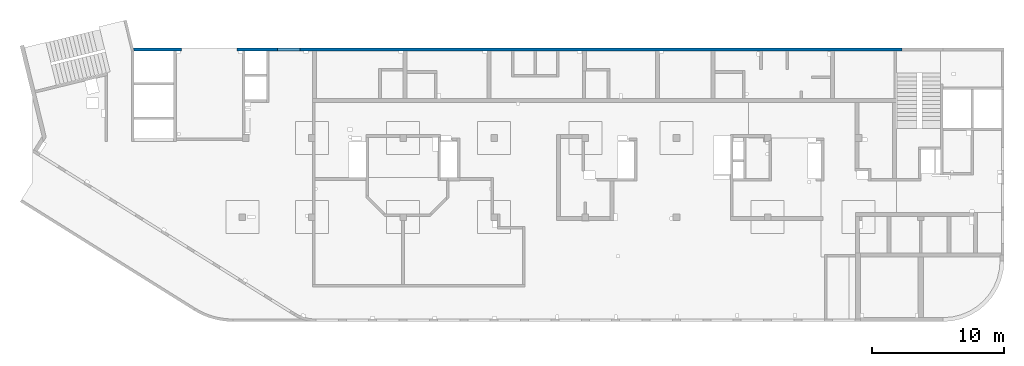
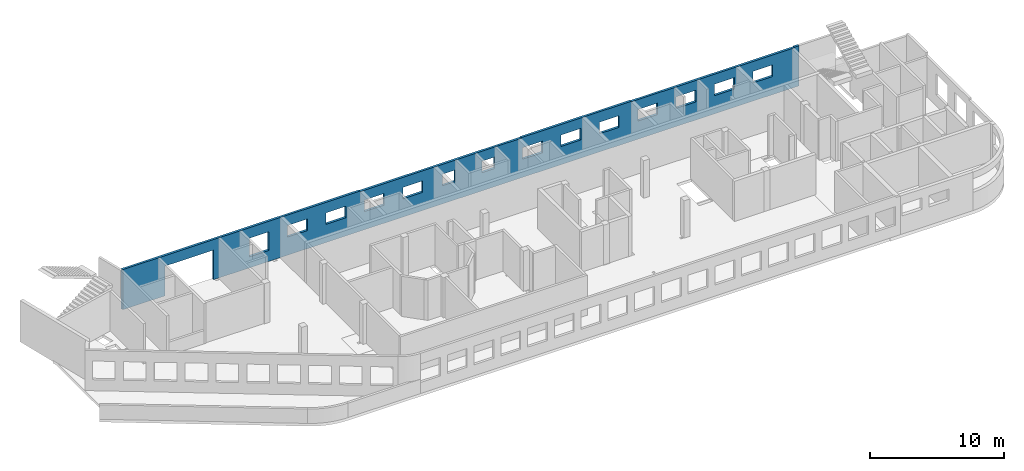
# One storey, part 9 of 10: 1 wall, 15 openings.
"""IFC4 building model written with IfcOpenShell, lengths in millimetres."""

from ifc_helpers import new_model, entity, si_unit, converted_unit, derived_unit, direction, frame, origin, place, context, subcontext, project, spatial, indexed_curve, outline, extrude, polygons, material, type_object, element, save


model = new_model("IFC4")

# Units and contexts
model_context = context("Model", 3, precision=0.01, world=origin(), true_north=direction((6.12303176911189e-17, 1.0)))
plan_context = context("Plan", 3, precision=0.01, world=origin(), true_north=direction((6.12303176911189e-17, 1.0)))
body_context = subcontext(model_context, "Body", "Model", "MODEL_VIEW")
ifc_project = project(units=[si_unit("LENGTHUNIT", "METRE", prefix="MILLI"), si_unit("AREAUNIT", "SQUARE_METRE"), si_unit("VOLUMEUNIT", "CUBIC_METRE"), converted_unit("PLANEANGLEUNIT", "DEGREE", entity("IfcRatioMeasure", 0.0174532925199433), si_unit("PLANEANGLEUNIT", "RADIAN"), dimensions=[0, 0, 0, 0, 0, 0, 0]), si_unit("MASSUNIT", "GRAM", prefix="KILO"), derived_unit("MASSDENSITYUNIT", [(si_unit("MASSUNIT", "GRAM", prefix="KILO"), 1), (si_unit("LENGTHUNIT", "METRE"), -3)]), derived_unit("MOMENTOFINERTIAUNIT", [(si_unit("LENGTHUNIT", "METRE"), 4)]), si_unit("TIMEUNIT", "SECOND"), si_unit("FREQUENCYUNIT", "HERTZ"), si_unit("THERMODYNAMICTEMPERATUREUNIT", "DEGREE_CELSIUS"), derived_unit("THERMALTRANSMITTANCEUNIT", [(si_unit("MASSUNIT", "GRAM", prefix="KILO"), 1), (si_unit("THERMODYNAMICTEMPERATUREUNIT", "KELVIN"), -1), (si_unit("TIMEUNIT", "SECOND"), -3)]), derived_unit("VOLUMETRICFLOWRATEUNIT", [(si_unit("LENGTHUNIT", "METRE"), 3), (si_unit("TIMEUNIT", "SECOND"), -1)]), derived_unit("MASSFLOWRATEUNIT", [(si_unit("MASSUNIT", "GRAM", prefix="KILO"), 1), (si_unit("TIMEUNIT", "SECOND"), -1)]), derived_unit("ROTATIONALFREQUENCYUNIT", [(si_unit("TIMEUNIT", "SECOND"), -1)]), si_unit("ELECTRICCURRENTUNIT", "AMPERE"), si_unit("ELECTRICVOLTAGEUNIT", "VOLT"), si_unit("POWERUNIT", "WATT"), si_unit("FORCEUNIT", "NEWTON", prefix="KILO"), si_unit("ILLUMINANCEUNIT", "LUX"), si_unit("LUMINOUSFLUXUNIT", "LUMEN"), si_unit("LUMINOUSINTENSITYUNIT", "CANDELA"), derived_unit("USERDEFINED", [(si_unit("MASSUNIT", "GRAM", prefix="KILO"), -1), (si_unit("LENGTHUNIT", "METRE"), -2), (si_unit("TIMEUNIT", "SECOND"), 3), (si_unit("LUMINOUSFLUXUNIT", "LUMEN"), 1)]), derived_unit("LINEARVELOCITYUNIT", [(si_unit("LENGTHUNIT", "METRE"), 1), (si_unit("TIMEUNIT", "SECOND"), -1)]), si_unit("PRESSUREUNIT", "PASCAL"), derived_unit("USERDEFINED", [(si_unit("LENGTHUNIT", "METRE"), -2), (si_unit("MASSUNIT", "GRAM", prefix="KILO"), 1), (si_unit("TIMEUNIT", "SECOND"), -2)]), derived_unit("LINEARFORCEUNIT", [(si_unit("MASSUNIT", "GRAM", prefix="KILO"), 1), (si_unit("LENGTHUNIT", "METRE"), 1), (si_unit("TIMEUNIT", "SECOND"), -2), (si_unit("LENGTHUNIT", "METRE"), -1)]), derived_unit("PLANARFORCEUNIT", [(si_unit("MASSUNIT", "GRAM", prefix="KILO"), 1), (si_unit("LENGTHUNIT", "METRE"), 1), (si_unit("TIMEUNIT", "SECOND"), -2), (si_unit("LENGTHUNIT", "METRE"), -2)])], contexts=[model_context, plan_context])

# Site, building, storey
site_placement = place(None, origin())
site = spatial("IfcSite", under=ifc_project, at=site_placement, CompositionType="ELEMENT")
building_placement = place(site_placement, origin())
building = spatial("IfcBuilding", under=site, at=building_placement, CompositionType="ELEMENT")
storey_placement = place(building_placement, frame((0.0, 0.0, 4200.0)))
storey = spatial("IfcBuildingStorey", under=building, at=storey_placement, CompositionType="ELEMENT", Elevation=4200.0)

# Wall, openings
ifc_material = material()
wall_type = type_object("IfcWallType", PredefinedType="STANDARD")
wall_placement = place(storey_placement, frame((7650.64481206478, 20399.9992263564, -150.0)))
wall = element("IfcWall", 1, at=wall_placement, inside=storey, type_object=wall_type, material=ifc_material, PredefinedType="NOTDEFINED", context=body_context, shape_type="Tessellation", body=[
    polygons([(58179.3554564899, -99.9999999999989, 5.41433564649196e-13), (58179.3554564899, -99.9999999999989, 3650.0), (57779.3554564899, -99.9999999999989, 3650.0), (57779.3554564899, -99.9999999999989, 3600.0), (57579.3554564899, -99.9999999999989, 3600.0), (53069.3554564899, -99.9999999999989, 3600.0), (52769.3554564899, -99.9999999999989, 3600.0), (52629.3554564899, -99.9999999999989, 3600.0), (52429.3554564898, -99.9999999999989, 3600.0), (49619.3554564899, -99.9999999999989, 3600.0), (49419.3554564899, -99.9999999999989, 3600.0), (47619.3554564899, -99.9999999999989, 3600.0), (47419.3554564899, -99.9999999999989, 3600.0), (47219.3554564898, -99.9999999999989, 3600.0), (44039.3554564899, -99.9999999999989, 3600.0), (43739.3554564901, -99.9999999999989, 3600.0), (43739.3554564901, -99.9999999999989, 3650.0), (39819.3554564899, -99.9999999999989, 3650.0), (39519.3554564899, -99.9999999999989, 3650.0), (34319.3554564899, -99.9999999999989, 3650.0), (34319.3554564899, -99.9999999999989, 3600.0), (34019.3554564899, -99.9999999999989, 3600.0), (32219.3554564899, -99.9999999999989, 3600.0), (32019.3554564899, -99.9999999999989, 3600.0), (30519.3554564899, -99.9999999999989, 3600.0), (30319.3554564899, -99.9999999999989, 3600.0), (28819.3554564899, -99.9999999999989, 3600.0), (28619.3554564899, -99.9999999999989, 3600.0), (27069.3554564899, -99.9999999999989, 3600.0), (26769.3554564899, -99.9999999999989, 3600.0), (20719.3554564899, -99.9999999999989, 3600.0), (20419.3554564899, -99.9999999999989, 3600.0), (20419.3554564899, -99.9999999999989, 3650.0), (13869.3554564899, -99.9999999999989, 3650.0), (13569.3554564899, -99.9999999999989, 3650.0), (10274.3554564899, -99.9999999999989, 3650.0), (10074.3554564899, -99.9999999999989, 3650.0), (8449.3554564899, -99.9999999999989, 3650.0), (8249.3554564899, -99.9999999999989, 3650.0), (3249.35545648991, -99.9999999999989, 3650.0), (3049.35545648991, -99.9999999999989, 3650.0), (49.3554564899164, -99.9999999999989, 3650.0), (48.7521159583277, -99.9999999999989, 3650.0), (48.7521159583299, -99.9999999999989, 5.41433564649196e-13), (3049.35545648991, -99.9999999999989, 5.41433564649196e-13), (3249.35545648991, -99.9999999999989, 5.41433564649196e-13), (3549.35545648986, -99.9999999999989, 5.41433564649196e-13), (3649.35545648994, -99.9999999999989, 5.41433564649196e-13), (3649.35545648994, -99.9999999999989, 2699.99999999804), (7849.35545648994, -99.9999999999989, 2699.99999999804), (7849.35545648994, -99.9999999999989, 5.41433564649196e-13), (7949.35545648986, -99.9999999999989, 5.41433564649196e-13), (8249.35545648991, -99.9999999999989, 5.41433564649196e-13), (8449.3554564899, -99.9999999999989, 5.41433564649196e-13), (10074.3554564899, -99.9999999999989, 5.41433564649196e-13), (10274.3554564899, -99.9999999999989, 5.41433564649196e-13), (12919.3554564898, -99.9999999999989, 5.41433564649196e-13), (13219.3554564898, -99.9999999999989, 5.41433564649196e-13), (13569.3554564899, -99.9999999999989, 5.41433564649196e-13), (13869.3554564899, -99.9999999999989, 5.41433564649196e-13), (20119.3554564898, -99.9999999999989, 5.41433564649196e-13), (20419.3554564899, -99.9999999999989, 5.41433564649196e-13), (20719.3554564899, -99.9999999999989, 5.41433564649196e-13), (26469.3554564898, -99.9999999999989, 5.41433564649196e-13), (26769.3554564899, -99.9999999999989, 5.41433564649196e-13), (27069.3554564899, -99.9999999999989, 5.41433564649196e-13), (28619.3554564899, -99.9999999999989, 5.41433564649196e-13), (28819.3554564899, -99.9999999999989, 5.41433564649196e-13), (30319.3554564899, -99.9999999999989, 5.41433564649196e-13), (30519.3554564899, -99.9999999999989, 5.41433564649196e-13), (32019.3554564899, -99.9999999999989, 5.41433564649196e-13), (32219.3554564899, -99.9999999999989, 5.41433564649196e-13), (33619.3554564899, -99.9999999999989, 5.41433564649196e-13), (33919.3554564899, -99.9999999999989, 5.41433564649196e-13), (34019.3554564899, -99.9999999999989, 5.41433564649196e-13), (34319.3554564899, -99.9999999999989, 5.41433564649196e-13), (39519.3554564899, -99.9999999999989, 5.41433564649196e-13), (39819.3554564899, -99.9999999999989, 5.41433564649196e-13), (40119.3554564899, -99.9999999999989, 5.41433564649196e-13), (43739.3554564899, -99.9999999999989, 5.41433564649196e-13), (44039.3554564899, -99.9999999999989, 5.41433564649196e-13), (47419.3554564899, -99.9999999999989, 5.41433564649196e-13), (47619.3554564899, -99.9999999999989, 5.41433564649196e-13), (49419.3554564899, -99.9999999999989, 5.41433564649196e-13), (49619.3554564899, -99.9999999999989, 5.41433564649196e-13), (52769.3554564899, -99.9999999999989, 5.41433564649196e-13), (53069.3554564899, -99.9999999999989, 5.41433564649196e-13), (57579.3554564899, -99.9999999999989, 5.41433564649196e-13), (57779.3554564899, -99.9999999999989, 5.41433564649196e-13), (27519.3554564899, -99.9999999999989, 2700.0), (28619.3554564899, -99.9999999999989, 2700.0), (28619.3554564899, -99.9999999999989, 1650.00000000001), (27519.3554564899, -99.9999999999989, 1650.00000000001), (54219.3554564899, -99.9999999999989, 2700.0), (55919.3554564899, -99.9999999999989, 2700.0), (55919.3554564899, -99.9999999999989, 1650.00000000001), (54219.3554564899, -99.9999999999989, 1650.00000000001), (50919.3554564899, -99.9999999999989, 2700.0), (52619.3554564899, -99.9999999999989, 2700.0), (52619.3554564899, -99.9999999999989, 1650.00000000001), (50919.3554564899, -99.9999999999989, 1650.00000000001), (47619.3554564899, -99.9999999999989, 2700.0), (49319.3554564899, -99.9999999999989, 2700.0), (49319.3554564899, -99.9999999999989, 1650.00000000001), (47619.3554564899, -99.9999999999989, 1650.00000000001), (44319.3554564899, -99.9999999999989, 2700.0), (46019.3554564899, -99.9999999999989, 2700.0), (46019.3554564899, -99.9999999999989, 1650.00000000001), (44319.3554564899, -99.9999999999989, 1650.00000000001), (41019.3554564899, -99.9999999999989, 2700.0), (42719.3554564899, -99.9999999999989, 2700.0), (42719.3554564899, -99.9999999999989, 1650.00000000001), (41019.3554564899, -99.9999999999989, 1650.00000000001), (37719.3554564899, -99.9999999999989, 2700.0), (39419.3554564899, -99.9999999999989, 2700.0), (39419.3554564899, -99.9999999999989, 1650.00000000001), (37719.3554564899, -99.9999999999989, 1650.00000000001), (34419.3554564899, -99.9999999999946, 2700.0), (36119.3554564899, -99.9999999999989, 2700.0), (36119.3554564899, -99.9999999999989, 1650.00000000001), (34419.3554564899, -99.9999999999946, 1650.00000000001), (30919.3554564899, -99.9999999999989, 2700.0), (32019.3554564899, -99.9999999999989, 2700.0), (32019.3554564899, -99.9999999999989, 1650.00000000001), (30919.3554564899, -99.9999999999989, 1650.00000000001), (24119.3554564899, -99.9999999999989, 2700.0), (25819.3554564899, -99.9999999999989, 2700.0), (25819.3554564899, -99.9999999999989, 1650.00000000001), (24119.3554564899, -99.9999999999989, 1650.00000000001), (20819.3554564899, -99.9999999999989, 2700.0), (22519.3554564899, -99.9999999999989, 2700.0), (22519.3554564899, -99.9999999999989, 1650.00000000001), (20819.3554564899, -99.9999999999989, 1650.00000000001), (17519.3554564899, -99.9999999999989, 2700.0), (19219.3554564899, -100.000000000003, 2700.0), (19219.3554564899, -100.000000000003, 1650.00000000001), (17519.3554564899, -99.9999999999989, 1650.00000000001), (14219.3554564899, -99.9999999999989, 2700.0), (15919.3554564899, -99.9999999999989, 2700.0), (15919.3554564899, -99.9999999999989, 1650.00000000001), (14219.3554564899, -99.9999999999989, 1650.00000000001), (10919.3554564899, -99.9999999999989, 2700.0), (12619.3554564899, -99.9999999999989, 2700.0), (12619.3554564899, -99.9999999999989, 1000.00000000001), (10919.3554564899, -99.9999999999989, 1000.00000000001), (58179.3554564899, 99.9999999999989, 3650.0), (58179.3554564899, 99.9999999999989, 5.41433564649196e-13), (57779.3554564899, 99.9999999999989, 5.41433564649196e-13), (43739.3554564901, 99.9999999999989, 5.41433564649196e-13), (34319.3554564899, 99.9999999999989, 5.41433564649196e-13), (20419.3554564899, 99.9999999999989, 5.41433564649196e-13), (10074.3554564899, 99.9999999999989, 5.41433564649196e-13), (8449.35545648991, 99.9999999999989, 5.41433564649196e-13), (7849.35545648994, 99.9999999999989, 5.41433564649196e-13), (7849.35545648994, 99.9999999999989, 2699.99999999804), (3649.35545648994, 99.9999999999989, 2699.99999999804), (3649.35545648994, 99.9999999999989, 5.41433564649196e-13), (3049.35545648991, 99.9999999999989, 5.41433564649196e-13), (49.3554564899158, 99.9999999999989, 5.41433564649196e-13), (7.41714528604756e-14, 99.9999999999989, 5.41433564649196e-13), (1.15703858215887e-12, 99.9999999999989, 3650.0), (49.3554564899158, 99.9999999999989, 3650.0), (3049.35545648991, 99.9999999999989, 3650.0), (8449.35545648991, 99.9999999999989, 3650.0), (10074.3554564899, 99.9999999999989, 3650.0), (20419.3554564899, 99.9999999999989, 3650.0), (20419.3554564899, 99.9999999999989, 3600.0), (34319.3554564899, 99.9999999999989, 3600.0), (34319.3554564899, 99.9999999999989, 3650.0), (43739.3554564901, 99.9999999999989, 3650.0), (43739.3554564901, 99.9999999999903, 3600.0), (57779.3554564899, 99.9999999999903, 3600.0), (57779.3554564899, 99.9999999999989, 3650.0), (28619.3554564899, 100.000000000319, 2699.99999999999), (27519.3554564899, 100.000000000319, 2699.99999999999), (27519.3554564899, 100.000000000319, 1650.00000000001), (28619.3554564899, 100.000000000319, 1650.00000000001), (55919.3554564899, 100.000000000324, 2700.0), (54219.3554564899, 100.000000000324, 2700.0), (54219.3554564899, 100.000000000324, 1650.00000000001), (55919.3554564899, 100.000000000324, 1650.00000000001), (52619.3554564899, 100.000000000319, 2700.0), (50919.3554564899, 100.000000000324, 2700.0), (50919.3554564899, 100.000000000324, 1650.00000000001), (52619.3554564899, 100.000000000319, 1650.00000000001), (49319.3554564899, 100.000000000319, 2700.0), (47619.3554564899, 100.000000000324, 2700.0), (47619.3554564899, 100.000000000324, 1650.00000000001), (49319.3554564899, 100.000000000319, 1650.00000000001), (46019.3554564899, 100.000000000319, 2700.0), (44319.3554564899, 100.000000000319, 2700.0), (44319.3554564899, 100.000000000319, 1650.00000000001), (46019.3554564899, 100.000000000319, 1650.00000000001), (42719.3554564899, 100.000000000319, 2700.0), (41019.3554564899, 100.000000000319, 2700.0), (41019.3554564899, 100.000000000319, 1650.00000000001), (42719.3554564899, 100.000000000319, 1650.00000000001), (39419.3554564899, 100.000000000324, 2700.0), (37719.3554564899, 100.000000000319, 2700.0), (37719.3554564899, 100.000000000319, 1650.00000000001), (39419.3554564899, 100.000000000324, 1650.00000000001), (36119.3554564899, 100.000000000319, 2700.0), (34419.3554564899, 100.000000000324, 2700.0), (34419.3554564899, 100.000000000324, 1650.00000000001), (36119.3554564899, 100.000000000319, 1650.00000000001), (32019.3554564899, 100.000000000319, 2699.99999999999), (30919.3554564899, 100.000000000319, 2699.99999999999), (30919.3554564899, 100.000000000319, 1650.00000000001), (32019.3554564899, 100.000000000319, 1650.00000000001), (25819.3554564899, 100.000000000319, 2699.99999999999), (24119.3554564899, 100.000000000324, 2699.99999999999), (24119.3554564899, 100.000000000324, 1650.00000000001), (25819.3554564899, 100.000000000319, 1650.00000000001), (22519.3554564899, 100.000000000319, 2699.99999999999), (20819.3554564899, 100.000000000324, 2699.99999999999), (20819.3554564899, 100.000000000324, 1650.00000000001), (22519.3554564899, 100.000000000319, 1650.00000000001), (19219.3554564899, 100.000000000319, 2699.99999999999), (17519.3554564899, 100.000000000319, 2699.99999999999), (17519.3554564899, 100.000000000319, 1650.00000000001), (19219.3554564899, 100.000000000319, 1650.00000000001), (15919.3554564899, 100.000000000319, 2699.99999999999), (14219.3554564899, 100.000000000319, 2699.99999999999), (14219.3554564899, 100.000000000319, 1650.00000000001), (15919.3554564899, 100.000000000319, 1650.00000000001), (12619.3554564899, 100.000000000319, 2700.0), (10919.3554564899, 100.000000000319, 2700.0), (10919.3554564899, 100.000000000319, 1000.00000000001), (12619.3554564899, 100.000000000319, 1000.00000000001)], [[[1, 2, 3, 4, 5, 6, 7, 8, 9, 10, 11, 12, 13, 14, 15, 16, 17, 18, 19, 20, 21, 22, 23, 24, 25, 26, 27, 28, 29, 30, 31, 32, 33, 34, 35, 36, 37, 38, 39, 40, 41, 42, 43, 44, 45, 46, 47, 48, 49, 50, 51, 52, 53, 54, 55, 56, 57, 58, 59, 60, 61, 62, 63, 64, 65, 66, 67, 68, 69, 70, 71, 72, 73, 74, 75, 76, 77, 78, 79, 80, 81, 82, 83, 84, 85, 86, 87, 88, 89], [90, 91, 92, 93], [94, 95, 96, 97], [98, 99, 100, 101], [102, 103, 104, 105], [106, 107, 108, 109], [110, 111, 112, 113], [114, 115, 116, 117], [118, 119, 120, 121], [122, 123, 124, 125], [126, 127, 128, 129], [130, 131, 132, 133], [134, 135, 136, 137], [138, 139, 140, 141], [142, 143, 144, 145]], [[146, 147, 148, 149, 150, 151, 152, 153, 154, 155, 156, 157, 158, 159, 160, 161, 162, 163, 164, 165, 166, 167, 168, 169, 170, 171, 172, 173], [174, 175, 176, 177], [178, 179, 180, 181], [182, 183, 184, 185], [186, 187, 188, 189], [190, 191, 192, 193], [194, 195, 196, 197], [198, 199, 200, 201], [202, 203, 204, 205], [206, 207, 208, 209], [210, 211, 212, 213], [214, 215, 216, 217], [218, 219, 220, 221], [222, 223, 224, 225], [226, 227, 228, 229]], [[44, 160, 159, 158, 157, 48, 47, 46, 45]], [[2, 1, 147, 146]], [[44, 43, 161, 160]], [[165, 164, 38, 37]], [[2, 146, 173, 3]], [[163, 162, 42, 41]], [[33, 32, 167, 166]], [[169, 168, 21, 20]], [[43, 42, 162, 161]], [[41, 40, 39, 38, 164, 163]], [[165, 37, 36, 35, 34, 33, 166]], [[20, 19, 18, 17, 170, 169]], [[32, 31, 30, 29, 28, 27, 26, 25, 24, 23, 22, 21, 168, 167]], [[175, 174, 91, 90]], [[175, 90, 93, 176]], [[176, 93, 92, 177]], [[91, 174, 177, 92]], [[179, 178, 95, 94]], [[179, 94, 97, 180]], [[180, 97, 96, 181]], [[95, 178, 181, 96]], [[183, 182, 99, 98]], [[183, 98, 101, 184]], [[184, 101, 100, 185]], [[99, 182, 185, 100]], [[187, 186, 103, 102]], [[187, 102, 105, 188]], [[188, 105, 104, 189]], [[103, 186, 189, 104]], [[191, 190, 107, 106]], [[191, 106, 109, 192]], [[192, 109, 108, 193]], [[107, 190, 193, 108]], [[195, 194, 111, 110]], [[195, 110, 113, 196]], [[196, 113, 112, 197]], [[111, 194, 197, 112]], [[199, 198, 115, 114]], [[199, 114, 117, 200]], [[200, 117, 116, 201]], [[115, 198, 201, 116]], [[203, 202, 119, 118]], [[203, 118, 121, 204]], [[204, 121, 120, 205]], [[119, 202, 205, 120]], [[207, 206, 123, 122]], [[207, 122, 125, 208]], [[208, 125, 124, 209]], [[123, 206, 209, 124]], [[211, 210, 127, 126]], [[211, 126, 129, 212]], [[212, 129, 128, 213]], [[127, 210, 213, 128]], [[215, 214, 131, 130]], [[215, 130, 133, 216]], [[216, 133, 132, 217]], [[131, 214, 217, 132]], [[219, 218, 135, 134]], [[219, 134, 137, 220]], [[220, 137, 136, 221]], [[135, 218, 221, 136]], [[223, 222, 139, 138]], [[223, 138, 141, 224]], [[224, 141, 140, 225]], [[139, 222, 225, 140]], [[227, 226, 143, 142]], [[227, 142, 145, 228]], [[228, 145, 144, 229]], [[143, 226, 229, 144]], [[49, 156, 155, 50]], [[50, 155, 154, 51]], [[156, 49, 48, 157]], [[4, 172, 171, 16, 15, 14, 13, 12, 11, 10, 9, 8, 7, 6, 5]], [[16, 171, 170, 17]], [[172, 4, 3, 173]], [[147, 1, 89, 88, 87, 86, 85, 84, 83, 82, 81, 80, 79, 78, 77, 76, 75, 74, 73, 72, 71, 70, 69, 68, 67, 66, 65, 64, 63, 62, 61, 60, 59, 58, 57, 56, 55, 54, 53, 52, 51, 154, 153, 152, 151, 150, 149, 148]]], closed=True),
])
opening_1_placement = place(wall_placement, frame((-7650.64481206478, -20399.9992263564, 150.0)))
element("IfcOpeningElement", 2, at=opening_1_placement, cuts=wall, PredefinedType="OPENING", context=body_context, shape_type="SweptSolid", body=[
    extrude(outline(indexed_curve([(-2100.0, -1349.99999999902), (2100.0, -1349.99999999902), (2100.0, 1349.99999999902), (-2100.0, 1349.99999999902), (-2100.0, -1349.99999999902)], self_intersect=False)), frame((13400.0002685547, 20199.9992263544, 1200.0), z_axis=(0.0, 1.0, 0.0), x_axis=(1.0, 0.0, 0.0)), (0.0, 0.0, 1.0), 400.000000001945),
])
opening_2_placement = place(wall_placement, frame((-7650.64481206478, -20399.9992263564, 150.0)))
element("IfcOpeningElement", 3, at=opening_2_placement, cuts=wall, PredefinedType="OPENING", context=body_context, shape_type="SweptSolid", body=[
    extrude(outline(indexed_curve([(-849.999999999993, -850.000000000002), (849.999999999994, -850.000000000002), (849.999999999994, 850.0), (-849.999999999993, 850.0), (-849.999999999993, -850.000000000002)], self_intersect=False)), frame((19420.0002685547, 20299.9992263564, 1700.0), z_axis=(0.0, 1.0, 0.0), x_axis=(0.0, 0.0, -1.0)), (0.0, 0.0, 1.0), 200.000000000959),
])
opening_3_placement = place(wall_placement, frame((-7650.64481206478, -20399.9992263564, 150.0)))
element("IfcOpeningElement", 4, at=opening_3_placement, cuts=wall, PredefinedType="OPENING", context=body_context, shape_type="SweptSolid", body=[
    extrude(outline(indexed_curve([(-524.999999999993, -850.000000000002), (524.999999999993, -850.000000000002), (524.999999999993, 849.999999999997), (-524.999999999993, 849.999999999997), (-524.999999999993, -850.000000000002)], self_intersect=False)), frame((22720.0002685547, 20299.9992263564, 2025.0), z_axis=(0.0, 1.0, 0.0), x_axis=(0.0, 0.0, -1.0)), (0.0, 0.0, 1.0), 200.000000000959),
])
opening_4_placement = place(wall_placement, frame((-7650.64481206478, -20399.9992263564, 150.0)))
element("IfcOpeningElement", 5, at=opening_4_placement, cuts=wall, PredefinedType="OPENING", context=body_context, shape_type="SweptSolid", body=[
    extrude(outline(indexed_curve([(-524.999999999993, -850.000000000002), (524.999999999993, -850.000000000002), (524.999999999993, 849.999999999997), (-524.999999999993, 849.999999999997), (-524.999999999993, -850.000000000002)], self_intersect=False)), frame((26020.0002685547, 20299.9992263563, 2025.0), z_axis=(0.0, 1.0, 0.0), x_axis=(0.0, 0.0, -1.0)), (0.0, 0.0, 1.0), 200.000000000959),
])
opening_5_placement = place(wall_placement, frame((-7650.64481206478, -20399.9992263564, 150.0)))
element("IfcOpeningElement", 6, at=opening_5_placement, cuts=wall, PredefinedType="OPENING", context=body_context, shape_type="SweptSolid", body=[
    extrude(outline(indexed_curve([(-524.999999999993, -849.999999999997), (524.999999999993, -849.999999999997), (524.999999999993, 850.000000000002), (-524.999999999993, 850.000000000002), (-524.999999999993, -849.999999999997)], self_intersect=False)), frame((29320.0002685547, 20299.9992263563, 2025.0), z_axis=(0.0, 1.0, 0.0), x_axis=(0.0, 0.0, -1.0)), (0.0, 0.0, 1.0), 200.000000000959),
])
opening_6_placement = place(wall_placement, frame((-7650.64481206478, -20399.9992263564, 150.0)))
element("IfcOpeningElement", 7, at=opening_6_placement, cuts=wall, PredefinedType="OPENING", context=body_context, shape_type="SweptSolid", body=[
    extrude(outline(indexed_curve([(-524.999999999993, -850.000000000002), (524.999999999993, -850.000000000002), (524.999999999993, 849.999999999997), (-524.999999999993, 849.999999999997), (-524.999999999993, -850.000000000002)], self_intersect=False)), frame((32620.0002685547, 20299.9992263563, 2025.0), z_axis=(0.0, 1.0, 0.0), x_axis=(0.0, 0.0, -1.0)), (0.0, 0.0, 1.0), 200.000000000959),
])
opening_7_placement = place(wall_placement, frame((-7650.64481206478, -20399.9992263564, 150.0)))
element("IfcOpeningElement", 8, at=opening_7_placement, cuts=wall, PredefinedType="OPENING", context=body_context, shape_type="SweptSolid", body=[
    extrude(outline(indexed_curve([(-524.999999999993, -549.999999999996), (524.999999999993, -549.999999999996), (524.999999999993, 550.000000000001), (-524.999999999993, 550.000000000001), (-524.999999999993, -549.999999999996)], self_intersect=False)), frame((39120.0002685547, 20299.9992263563, 2025.0), z_axis=(0.0, 1.0, 0.0), x_axis=(0.0, 0.0, -1.0)), (0.0, 0.0, 1.0), 200.000000000959),
])
opening_8_placement = place(wall_placement, frame((-7650.64481206478, -20399.9992263564, 150.0)))
element("IfcOpeningElement", 9, at=opening_8_placement, cuts=wall, PredefinedType="OPENING", context=body_context, shape_type="SweptSolid", body=[
    extrude(outline(indexed_curve([(-524.999999999993, -850.000000000006), (524.999999999993, -850.000000000006), (524.999999999993, 849.999999999997), (-524.999999999993, 849.999999999997), (-524.999999999993, -850.000000000006)], self_intersect=False)), frame((42920.0002685547, 20299.9992263563, 2025.0), z_axis=(0.0, 1.0, 0.0), x_axis=(0.0, 0.0, -1.0)), (0.0, 0.0, 1.0), 200.000000000959),
])
opening_9_placement = place(wall_placement, frame((-7650.64481206478, -20399.9992263564, 150.0)))
element("IfcOpeningElement", 10, at=opening_9_placement, cuts=wall, PredefinedType="OPENING", context=body_context, shape_type="SweptSolid", body=[
    extrude(outline(indexed_curve([(-524.999999999993, -850.000000000006), (524.999999999993, -850.000000000006), (524.999999999993, 849.999999999997), (-524.999999999993, 849.999999999997), (-524.999999999993, -850.000000000006)], self_intersect=False)), frame((46220.0002685547, 20299.9992263563, 2025.0), z_axis=(0.0, 1.0, 0.0), x_axis=(0.0, 0.0, -1.0)), (0.0, 0.0, 1.0), 200.000000000959),
])
opening_10_placement = place(wall_placement, frame((-7650.64481206478, -20399.9992263564, 150.0)))
element("IfcOpeningElement", 11, at=opening_10_placement, cuts=wall, PredefinedType="OPENING", context=body_context, shape_type="SweptSolid", body=[
    extrude(outline(indexed_curve([(-524.999999999993, -850.000000000006), (524.999999999993, -850.000000000006), (524.999999999993, 849.999999999997), (-524.999999999993, 849.999999999997), (-524.999999999993, -850.000000000006)], self_intersect=False)), frame((49520.0002685547, 20299.9992263563, 2025.0), z_axis=(0.0, 1.0, 0.0), x_axis=(0.0, 0.0, -1.0)), (0.0, 0.0, 1.0), 200.000000000959),
])
opening_11_placement = place(wall_placement, frame((-7650.64481206478, -20399.9992263564, 150.0)))
element("IfcOpeningElement", 12, at=opening_11_placement, cuts=wall, PredefinedType="OPENING", context=body_context, shape_type="SweptSolid", body=[
    extrude(outline(indexed_curve([(-524.999999999993, -849.999999999997), (524.999999999993, -849.999999999997), (524.999999999993, 850.000000000006), (-524.999999999993, 850.000000000006), (-524.999999999993, -849.999999999997)], self_intersect=False)), frame((52820.0002685547, 20299.9992263563, 2025.0), z_axis=(0.0, 1.0, 0.0), x_axis=(0.0, 0.0, -1.0)), (0.0, 0.0, 1.0), 200.000000000959),
])
opening_12_placement = place(wall_placement, frame((-7650.64481206478, -20399.9992263564, 150.0)))
element("IfcOpeningElement", 13, at=opening_12_placement, cuts=wall, PredefinedType="OPENING", context=body_context, shape_type="SweptSolid", body=[
    extrude(outline(indexed_curve([(-524.999999999993, -850.000000000006), (524.999999999993, -850.000000000006), (524.999999999993, 849.999999999997), (-524.999999999993, 849.999999999997), (-524.999999999993, -850.000000000006)], self_intersect=False)), frame((56120.0002685547, 20299.9992263562, 2025.0), z_axis=(0.0, 1.0, 0.0), x_axis=(0.0, 0.0, -1.0)), (0.0, 0.0, 1.0), 200.000000000959),
])
opening_13_placement = place(wall_placement, frame((-7650.64481206478, -20399.9992263564, 150.0)))
element("IfcOpeningElement", 14, at=opening_13_placement, cuts=wall, PredefinedType="OPENING", context=body_context, shape_type="SweptSolid", body=[
    extrude(outline(indexed_curve([(-524.999999999993, -850.000000000006), (524.999999999993, -850.000000000006), (524.999999999993, 849.999999999997), (-524.999999999993, 849.999999999997), (-524.999999999993, -850.000000000006)], self_intersect=False)), frame((59420.0002685547, 20299.9992263562, 2025.0), z_axis=(0.0, 1.0, 0.0), x_axis=(0.0, 0.0, -1.0)), (0.0, 0.0, 1.0), 200.000000000959),
])
opening_14_placement = place(wall_placement, frame((-7650.64481206478, -20399.9992263564, 150.0)))
element("IfcOpeningElement", 15, at=opening_14_placement, cuts=wall, PredefinedType="OPENING", context=body_context, shape_type="SweptSolid", body=[
    extrude(outline(indexed_curve([(-524.999999999993, -850.000000000006), (524.999999999993, -850.000000000006), (524.999999999993, 849.999999999997), (-524.999999999993, 849.999999999997), (-524.999999999993, -850.000000000006)], self_intersect=False)), frame((62720.0002685547, 20299.9992263562, 2025.0), z_axis=(0.0, 1.0, 0.0), x_axis=(0.0, 0.0, -1.0)), (0.0, 0.0, 1.0), 200.000000000959),
])
opening_15_placement = place(wall_placement, frame((-7650.64481206478, -20399.9992263564, 150.0)))
element("IfcOpeningElement", 16, at=opening_15_placement, cuts=wall, PredefinedType="OPENING", context=body_context, shape_type="SweptSolid", body=[
    extrude(outline(indexed_curve([(-524.999999999993, -550.000000000001), (524.999999999993, -550.000000000001), (524.999999999993, 550.000000000001), (-524.999999999993, 550.000000000001), (-524.999999999993, -550.000000000001)], self_intersect=False)), frame((35720.0002685547, 20299.9992263563, 2025.0), z_axis=(0.0, 1.0, 0.0), x_axis=(0.0, 0.0, -1.0)), (0.0, 0.0, 1.0), 200.000000000959),
])

save(model, "model.ifc")
